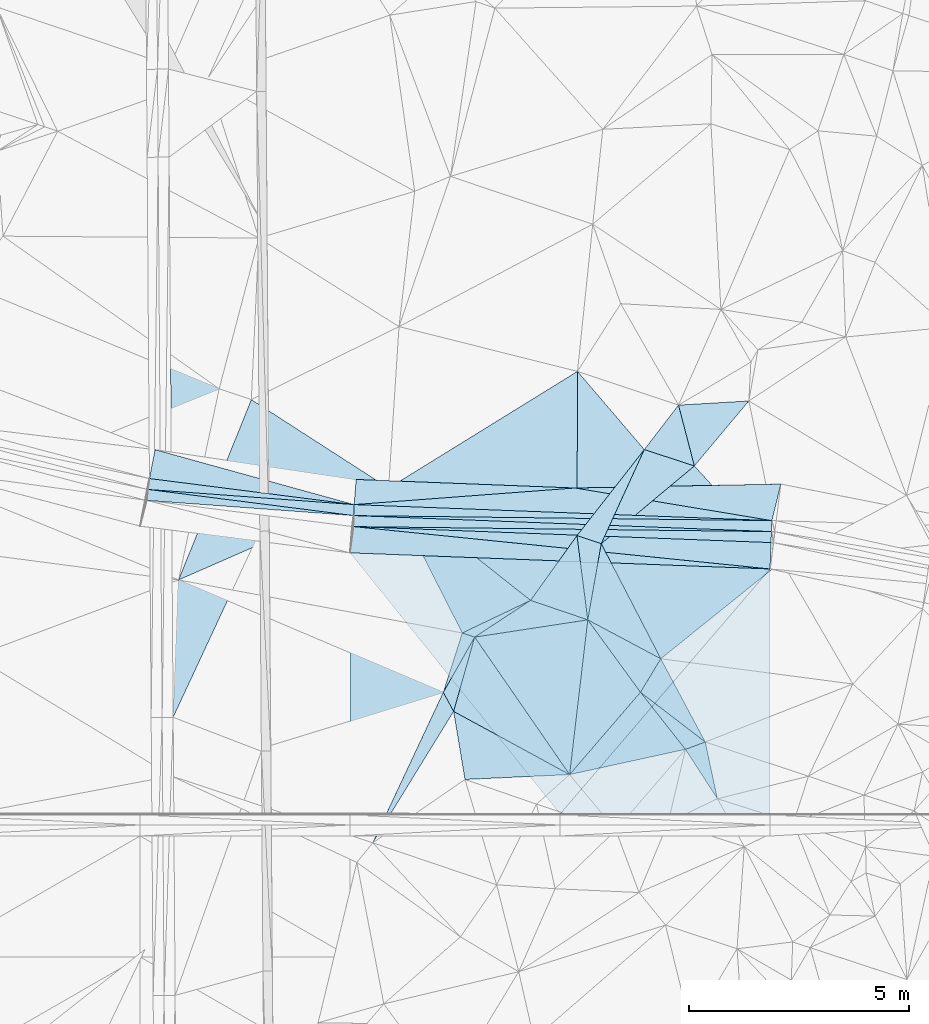
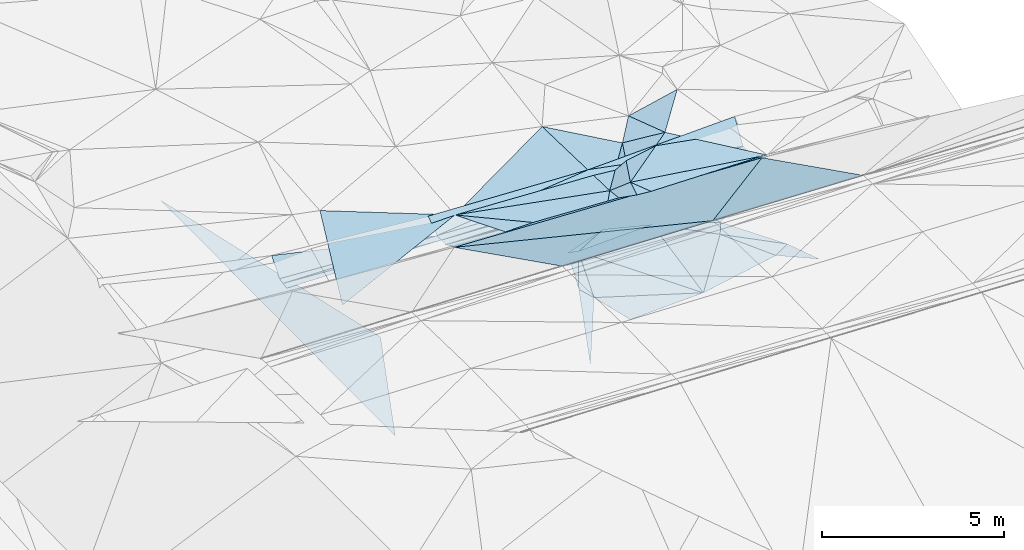
# One storey, part 115 of 275: 45 plates.
"""IFC2X3 building model written with IfcOpenShell, lengths in millimetres."""

import ifcopenshell
import ifcopenshell.guid

model = None  # the IFC model being written
_history = None  # IfcOwnerHistory: only IFC2X3 demands one
_inside = {}  # id of a spatial element -> (the spatial element, [elements in it])
_under = {}  # id of a project, library or spatial element -> (it, [spatial elements below it])
_declared = {}  # id of a project -> (the project, [libraries it declares])
_typed = {}  # id of a type object -> (the type object, [elements of that type])
_made_of = {}  # id of a material, layer set ... -> (it, [elements and type objects made of it])


def new_model(schema):
    """Start an empty IFC model of exactly this schema.

    Asked for "IFC4X3", IfcOpenShell would pick the latest addendum, in which some entities
    have other attributes; the version numbers below select the first issue.
    IFC2X3 requires an IfcOwnerHistory on every rooted entity: one is made here for all.
    """
    global model, _history
    if schema == "IFC4X3":
        model = ifcopenshell.file(schema_version=(4, 3, 0, 0))
    else:
        model = ifcopenshell.file(schema=schema)
    _inside.clear()
    _under.clear()
    _declared.clear()
    _typed.clear()
    _made_of.clear()
    _history = None
    if model.schema == "IFC2X3":
        org = make("IfcOrganization", Name="unknown")
        user = make(
            "IfcPersonAndOrganization",
            ThePerson=make("IfcPerson", FamilyName="unknown"),
            TheOrganization=org,
        )
        app = make(
            "IfcApplication",
            ApplicationDeveloper=org,
            Version="unknown",
            ApplicationFullName="unknown",
            ApplicationIdentifier="unknown",
        )
        _history = make(
            "IfcOwnerHistory",
            OwningUser=user,
            OwningApplication=app,
            ChangeAction="ADDED",
            CreationDate=0,
        )
    return model


def make(cls, **values):
    """One entity of the class cls with the attributes given. An attribute that is None is left unset."""
    return model.create_entity(
        cls, **{name: value for name, value in values.items() if value is not None}
    )


def rooted(cls, **values):
    """An entity with a GlobalId (a new one), such as an element, a storey or a relation."""
    return make(cls, GlobalId=ifcopenshell.guid.new(), OwnerHistory=_history, **values)


def si_unit(unit_type, name, prefix=None):
    """IfcSIUnit, for example si_unit("LENGTHUNIT", "METRE", prefix="MILLI")."""
    return make("IfcSIUnit", UnitType=unit_type, Prefix=prefix, Name=name)


def assignment(units):
    """IfcUnitAssignment: the units of a project."""
    return None if units is None else make("IfcUnitAssignment", Units=units)


def point(xyz):
    """IfcCartesianPoint."""
    return None if xyz is None else make("IfcCartesianPoint", Coordinates=xyz)


def direction(xyz):
    """IfcDirection."""
    return None if xyz is None else make("IfcDirection", DirectionRatios=xyz)


def frame(location, z_axis=None, x_axis=None):
    """IfcAxis2Placement3D, a coordinate frame: its origin and axes. An axis left out is left unset."""
    return make(
        "IfcAxis2Placement3D",
        Location=point(location),
        Axis=direction(z_axis),
        RefDirection=direction(x_axis),
    )


def origin_with_axes():
    """The frame at (0, 0, 0) with the z axis (0, 0, 1) and the x axis (1, 0, 0) written out."""
    return frame((0.0, 0.0, 0.0), z_axis=(0.0, 0.0, 1.0), x_axis=(1.0, 0.0, 0.0))


def place(relative_to, where):
    """IfcLocalPlacement: puts the frame where relative to a parent placement (None: the world)."""
    return make(
        "IfcLocalPlacement", PlacementRelTo=relative_to, RelativePlacement=where
    )


def context(
    kind, dimensions, precision=None, world=None, true_north=None, identifier=None
):
    """IfcGeometricRepresentationContext, for example the 3D "Model" context."""
    return make(
        "IfcGeometricRepresentationContext",
        ContextIdentifier=identifier,
        ContextType=kind,
        CoordinateSpaceDimension=dimensions,
        Precision=precision,
        WorldCoordinateSystem=world,
        TrueNorth=true_north,
    )


def subcontext(parent, identifier, kind, view, scale=None):
    """IfcGeometricRepresentationSubContext, for example "Body" below "Model"."""
    return make(
        "IfcGeometricRepresentationSubContext",
        ContextIdentifier=identifier,
        ContextType=kind,
        ParentContext=parent,
        TargetScale=scale,
        TargetView=view,
    )


def project(units=None, contexts=None):
    """IfcProject with its units and contexts."""
    return rooted(
        "IfcProject",
        Name="project",
        RepresentationContexts=contexts,
        UnitsInContext=assignment(units),
    )


def spatial(cls, under=None, at=None, **own):
    """A site, building, storey or space (cls), placed at a placement, below another one or the project."""
    s = rooted(cls, ObjectPlacement=at, **own)
    if under is not None:
        _under.setdefault(under.id(), (under, []))[1].append(s)
    return s


def polyline(points):
    """IfcPolyline through the points."""
    return make("IfcPolyline", Points=[point(p) for p in points])


def outline(outer, holes=None, kind="AREA"):
    """IfcArbitraryClosedProfileDef: a profile drawn as a closed curve; with holes, ...WithVoids."""
    if holes is None:
        return make("IfcArbitraryClosedProfileDef", ProfileType=kind, OuterCurve=outer)
    return make(
        "IfcArbitraryProfileDefWithVoids",
        ProfileType=kind,
        OuterCurve=outer,
        InnerCurves=holes,
    )


def extrude(swept, where, along, depth):
    """IfcExtrudedAreaSolid: the profile swept, set in the frame where, extruded along a direction by depth."""
    return make(
        "IfcExtrudedAreaSolid",
        SweptArea=swept,
        Position=where,
        ExtrudedDirection=direction(along),
        Depth=depth,
    )


def shape(context_of_items, identifier, shape_type, items):
    """IfcShapeRepresentation: the items that make up one representation, for example the "Body"."""
    return make(
        "IfcShapeRepresentation",
        ContextOfItems=context_of_items,
        RepresentationIdentifier=identifier,
        RepresentationType=shape_type,
        Items=items,
    )


def material(Name=None, Category=None):
    """IfcMaterial."""
    return make("IfcMaterial", Name=Name, Category=Category)


def made_of(thing, what):
    """Note that an element or type object is made of a material, layer set ...; save() writes the relation."""
    if what is not None:
        _made_of.setdefault(what.id(), (what, []))[1].append(thing)
    return thing


def type_object(cls, material=None, **own):
    """A type object (cls), such as IfcWallType, which elements share."""
    return made_of(rooted(cls, **own), material)


def element(
    cls,
    number,
    at=None,
    inside=None,
    cuts=None,
    type_object=None,
    material=None,
    context=None,
    identifier="Body",
    shape_type=None,
    held_by="IfcProductDefinitionShape",
    body=None,
    shapes=None,
    **own,
):
    """One element of the class cls, such as IfcWall. Its Tag is "e" and its number.

    at: its placement. inside: the storey or other place that contains it. cuts: it is an
    opening in that element (IfcRelVoidsElement). A single representation is given by context,
    identifier, shape_type and body (its items); several are given by shapes. held_by: the class
    of the entity that holds the representations. save() writes the other relations.
    """
    e = rooted(cls, Tag="e%d" % number, ObjectPlacement=at, **own)
    if body is not None:
        shapes = [shape(context, identifier, shape_type, body)]
    if shapes is not None:
        e.Representation = make(held_by, Representations=shapes)
    if inside is not None:
        _inside.setdefault(inside.id(), (inside, []))[1].append(e)
    if cuts is not None:
        rooted(
            "IfcRelVoidsElement", RelatingBuildingElement=cuts, RelatedOpeningElement=e
        )
    if type_object is not None:
        _typed.setdefault(type_object.id(), (type_object, []))[1].append(e)
    return made_of(e, material)


def aggregate(whole, parts):
    """IfcRelAggregates: a whole, such as a stair, and the parts it consists of."""
    return rooted("IfcRelAggregates", RelatingObject=whole, RelatedObjects=parts)


def save(model, path):
    """Write the relations noted so far, then the file.

    IfcRelAggregates (storeys below a building ...), IfcRelContainedInSpatialStructure (elements
    in a storey), IfcRelDefinesByType, IfcRelAssociatesMaterial and IfcRelDeclares: one each for
    every whole, place, type object, material and project.
    """
    for whole, parts in _under.values():
        aggregate(whole, parts)
    for where, things in _inside.values():
        rooted(
            "IfcRelContainedInSpatialStructure",
            RelatedElements=things,
            RelatingStructure=where,
        )
    for kind, things in _typed.values():
        rooted("IfcRelDefinesByType", RelatedObjects=things, RelatingType=kind)
    for what, things in _made_of.values():
        rooted("IfcRelAssociatesMaterial", RelatedObjects=things, RelatingMaterial=what)
    for by, libraries in _declared.values():
        rooted("IfcRelDeclares", RelatingContext=by, RelatedDefinitions=libraries)
    model.write(path)


model = new_model("IFC2X3")

# Units and contexts
model_context = context("Model", 3, precision=1e-05, world=origin_with_axes())
body_context = subcontext(model_context, "Body", "Model", "MODEL_VIEW")
ifc_project = project(units=[si_unit("LENGTHUNIT", "METRE", prefix="MILLI"), si_unit("AREAUNIT", "SQUARE_METRE"), si_unit("VOLUMEUNIT", "CUBIC_METRE"), si_unit("MASSUNIT", "GRAM", prefix="KILO"), si_unit("TIMEUNIT", "SECOND"), si_unit("PLANEANGLEUNIT", "RADIAN"), si_unit("SOLIDANGLEUNIT", "STERADIAN"), si_unit("THERMODYNAMICTEMPERATUREUNIT", "DEGREE_CELSIUS"), si_unit("LUMINOUSINTENSITYUNIT", "LUMEN")], contexts=[model_context])

# Site, building, storey
site_placement = place(None, origin_with_axes())
site = spatial("IfcSite", under=ifc_project, at=site_placement, CompositionType="ELEMENT")
building_placement = place(site_placement, origin_with_axes())
building = spatial("IfcBuilding", under=site, at=building_placement, Name="Undefined", CompositionType="ELEMENT")
storey_placement = place(building_placement, origin_with_axes())
storey = spatial("IfcBuildingStorey", under=building, at=storey_placement, Name="Undefined", CompositionType="ELEMENT", Elevation=0.0)

# Plates
ifc_material = material()
plate_type_1 = type_object("IfcPlateType", PredefinedType="NOTDEFINED")
plate_1_placement = place(storey_placement, frame((-48294.1638789683, 73916.0486067391, 44928.8124257044), z_axis=(0.0352593844994931, -0.0212550121172629, -0.999152140699609), x_axis=(0.125694012946975, 0.991929064763121, -0.0166657009287537)))
element("IfcPlate", 1, at=plate_1_placement, inside=storey, type_object=plate_type_1, material=ifc_material, Name="00_PR", context=body_context, shape_type="SweptSolid", body=[
    extrude(outline(polyline([(0.0, 0.0), (250.034484863281, 6.54836185276508e-10), (244.383270263672, 4692.763671875), (0.0, 0.0)])), frame((-8.85201319254618e-08, 2.18876761149539e-07, -0.5000001331573), z_axis=(0.0, 0.0, 1.0), x_axis=(1.0, 0.0, 0.0)), (0.0, 0.0, 1.0), 1.0),
])
plate_2_placement = place(storey_placement, frame((-43620.39508708, 73322.0550243122, 45102.3810420952), z_axis=(-0.0121938043643869, -0.00344139705818809, -0.999919730739128), x_axis=(0.0381160409586329, 0.999265693644616, -0.00390396293327051)))
element("IfcPlate", 2, at=plate_2_placement, inside=storey, type_object=plate_type_1, material=ifc_material, Name="00_PR", context=body_context, shape_type="SweptSolid", body=[
    extrude(outline(polyline([(0.0, 0.0), (250.002349853516, -2.83762346953154e-10), (248.815231323242, 9503.3759765625), (0.0, 0.0)])), frame((-8.85201319254618e-08, 2.18876761149539e-07, -0.5000001331573), z_axis=(0.0, 0.0, 1.0), x_axis=(1.0, 0.0, 0.0)), (0.0, 0.0, 1.0), 1.0),
])
plate_3_placement = place(storey_placement, frame((-34124.7195421901, 72958.2183460982, 44986.8590393595), z_axis=(-0.0121527442326692, 0.000465623148121774, -0.999926044266624), x_axis=(-0.0382861419842661, -0.999266816887242, -6.99073876586366e-11)))
element("IfcPlate", 3, at=plate_3_placement, inside=storey, type_object=plate_type_1, material=ifc_material, Name="00_PR", context=body_context, shape_type="SweptSolid", body=[
    extrude(outline(polyline([(0.0, 0.0), (250.000045776367, 1.01863406598568e-09), (249.981430053711, 9498.8671875), (0.0, 0.0)])), frame((-8.85201319254618e-08, 2.18876761149539e-07, -0.5000001331573), z_axis=(0.0, 0.0, 1.0), x_axis=(1.0, 0.0, 0.0)), (0.0, 0.0, 1.0), 1.0),
])
plate_4_placement = place(storey_placement, frame((-43625.490880471, 73072.068163486, 45102.3810387833), z_axis=(-0.0121553558488457, 0.000247777014239796, -0.999926090234043), x_axis=(0.0203799450012853, 0.999792307352754, 6.91103637420199e-11)))
element("IfcPlate", 4, at=plate_4_placement, inside=storey, type_object=plate_type_1, material=ifc_material, Name="00_PR", context=body_context, shape_type="SweptSolid", body=[
    extrude(outline(polyline([(0.0, 0.0), (250.040634155273, -9.67702362686396e-10), (79.7989196777344, 9501.8203125), (0.0, 0.0)])), frame((-8.85201319254618e-08, 2.18876761149539e-07, -0.5000001331573), z_axis=(0.0, 0.0, 1.0), x_axis=(1.0, 0.0, 0.0)), (0.0, 0.0, 1.0), 1.0),
])
plate_5_placement = place(storey_placement, frame((-48318.9873284773, 73667.2003650453, 44928.8123364853), z_axis=(0.036441065400132, -0.00363507658490201, -0.999329192494008), x_axis=(0.0992595869970328, 0.995061573164786, 7.62530437417146e-11)))
element("IfcPlate", 5, at=plate_5_placement, inside=storey, type_object=plate_type_1, material=ifc_material, Name="00_PR", context=body_context, shape_type="SweptSolid", body=[
    extrude(outline(polyline([(0.0, 0.0), (250.09211730957, 0.0), (122.941780090332, 4712.8330078125), (0.0, 0.0)])), frame((-8.85201319254618e-08, 2.18876761149539e-07, -0.5000001331573), z_axis=(0.0, 0.0, 1.0), x_axis=(1.0, 0.0, 0.0)), (0.0, 0.0, 1.0), 1.0),
])
plate_6_placement = place(storey_placement, frame((-34115.1480022174, 73208.0351007316, 44986.8590386004), z_axis=(-0.0121470174228114, 0.000465403730693247, -0.999926113953975), x_axis=(-0.0382861419842661, -0.999266816887242, -6.99073876586366e-11)))
element("IfcPlate", 6, at=plate_6_placement, inside=storey, type_object=plate_type_1, material=ifc_material, Name="00_PR", context=body_context, shape_type="SweptSolid", body=[
    extrude(outline(polyline([(0.0, 0.0), (250.000045776367, 1.01863406598568e-09), (249.98095703125, 9503.345703125), (0.0, 0.0)])), frame((-8.85201319254618e-08, 2.18876761149539e-07, -0.5000001331573), z_axis=(0.0, 0.0, 1.0), x_axis=(1.0, 0.0, 0.0)), (0.0, 0.0, 1.0), 1.0),
])
plate_type_2 = type_object("IfcPlateType", PredefinedType="NOTDEFINED")
plate_7_placement = place(storey_placement, frame((-47815.5257000505, 81469.3146674335, 42970.4690775607), z_axis=(-0.000186197747615207, 0.0175987070443489, -0.999845113425458), x_axis=(0.235525740042379, -0.971716826060535, -0.0171474700270998)))
element("IfcPlate", 7, at=plate_7_placement, inside=storey, type_object=plate_type_2, material=ifc_material, Name="00_PR", context=body_context, shape_type="SweptSolid", body=[
    extrude(outline(polyline([(0.0, 0.0), (8751.0869140625, 1.57961039803922e-08), (12397.4677734375, 2910.38232421875), (0.0, 0.0)])), frame((-8.85201319254618e-08, 2.18876761149539e-07, -0.5000001331573), z_axis=(0.0, 0.0, 1.0), x_axis=(1.0, 0.0, 0.0)), (0.0, 0.0, 1.0), 1.0),
])
plate_type_3 = type_object("IfcPlateType", PredefinedType="NOTDEFINED")
plate_8_placement = place(storey_placement, frame((-38299.7541736473, 70952.5999806547, 45199.5002545505), z_axis=(-0.0129765998053604, 0.029664067349419, -0.99947568803137), x_axis=(-0.946487294587573, 0.322000893554466, 0.0218454968911747)))
element("IfcPlate", 8, at=plate_8_placement, inside=storey, type_object=plate_type_3, material=ifc_material, Name="00", context=body_context, shape_type="SweptSolid", body=[
    extrude(outline(polyline([(0.0, 0.0), (1373.28076171875, -1.00408215075731e-09), (849.644165039063, 1733.98522949219), (0.0, 0.0)])), frame((-8.85201319254618e-08, 2.18876761149539e-07, -0.5000001331573), z_axis=(0.0, 0.0, 1.0), x_axis=(1.0, 0.0, 0.0)), (0.0, 0.0, 1.0), 1.0),
])
plate_type_4 = type_object("IfcPlateType", PredefinedType="NOTDEFINED")
plate_9_placement = place(storey_placement, frame((-36237.0662744395, 75833.3351531522, 45159.5058776926), z_axis=(0.130062658848475, -0.0805188598307914, -0.9882309537678), x_axis=(0.250259449661486, -0.961760215188191, 0.111299129988942)))
element("IfcPlate", 9, at=plate_9_placement, inside=storey, type_object=plate_type_4, material=ifc_material, Name="00", context=body_context, shape_type="SweptSolid", body=[
    extrude(outline(polyline([(0.0, 0.0), (1437.5673828125, -6.98491930961609e-09), (775.268005371094, 1012.84722900391), (0.0, 0.0)])), frame((-8.85201319254618e-08, 2.18876761149539e-07, -0.5000001331573), z_axis=(0.0, 0.0, 1.0), x_axis=(1.0, 0.0, 0.0)), (0.0, 0.0, 1.0), 1.0),
])
plate_type_5 = type_object("IfcPlateType", PredefinedType="NOTDEFINED")
plate_10_placement = place(storey_placement, frame((-38544.5682656878, 72867.0351067597, 45259.5354862471), z_axis=(0.362270625941178, 0.0754788503161102, -0.929011806563913), x_axis=(0.897348791674895, -0.297765596324914, 0.325731170944499)))
element("IfcPlate", 10, at=plate_10_placement, inside=storey, type_object=plate_type_5, material=ifc_material, Name="00", context=body_context, shape_type="SweptSolid", body=[
    extrude(outline(polyline([(0.0, 0.0), (614.003234863281, 3.49245965480804e-10), (770.354248046875, 1770.63671875), (0.0, 0.0)])), frame((-8.85201319254618e-08, 2.18876761149539e-07, -0.5000001331573), z_axis=(0.0, 0.0, 1.0), x_axis=(1.0, 0.0, 0.0)), (0.0, 0.0, 1.0), 1.0),
])
plate_type_6 = type_object("IfcPlateType", PredefinedType="NOTDEFINED")
plate_11_placement = place(storey_placement, frame((-43610.8415277604, 73571.8748104233, 45101.4053396319), z_axis=(0.036724844030492, -0.00140083422017048, -0.999324433552199), x_axis=(-0.0381163309563892, -0.999273308617028, -6.34171355241828e-11)))
element("IfcPlate", 11, at=plate_11_placement, inside=storey, type_object=plate_type_6, material=ifc_material, Name="00_PR", context=body_context, shape_type="SweptSolid", body=[
    extrude(outline(polyline([(0.0, 0.0), (250.000442504883, 1.2732925824821e-09), (-165.422576904297, 4696.2099609375), (0.0, 0.0)])), frame((-8.85201319254618e-08, 2.18876761149539e-07, -0.5000001331573), z_axis=(0.0, 0.0, 1.0), x_axis=(1.0, 0.0, 0.0)), (0.0, 0.0, 1.0), 1.0),
])
plate_type_7 = type_object("IfcPlateType", PredefinedType="NOTDEFINED")
plate_12_placement = place(storey_placement, frame((-35877.2814056823, 74450.74555178, 45319.5085100628), z_axis=(0.170148167788889, -0.0694789403392727, -0.982966061391448), x_axis=(-0.250259449654528, 0.961760215189894, -0.111299129989871)))
element("IfcPlate", 12, at=plate_12_placement, inside=storey, type_object=plate_type_7, material=ifc_material, Name="00", context=body_context, shape_type="SweptSolid", body=[
    extrude(outline(polyline([(0.0, 0.0), (1437.5673828125, -6.98491930961609e-09), (1098.244140625, 1587.87902832031), (0.0, 0.0)])), frame((-8.85201319254618e-08, 2.18876761149539e-07, -0.5000001331573), z_axis=(0.0, 0.0, 1.0), x_axis=(1.0, 0.0, 0.0)), (0.0, 0.0, 1.0), 1.0),
])
plate_type_8 = type_object("IfcPlateType", PredefinedType="NOTDEFINED")
plate_13_placement = place(storey_placement, frame((-39599.5745177259, 71394.7162026286, 45229.5056149073), z_axis=(-0.068114263041179, -0.133134566190392, -0.988754587577551), x_axis=(0.946487294584048, -0.322000893564711, -0.0218454968929094)))
element("IfcPlate", 13, at=plate_13_placement, inside=storey, type_object=plate_type_8, material=ifc_material, Name="00", context=body_context, shape_type="SweptSolid", body=[
    extrude(outline(polyline([(0.0, 0.0), (1373.28076171875, -1.00408215075731e-09), (-938.264099121094, 1213.326171875), (0.0, 0.0)])), frame((-8.85201319254618e-08, 2.18876761149539e-07, -0.5000001331573), z_axis=(0.0, 0.0, 1.0), x_axis=(1.0, 0.0, 0.0)), (0.0, 0.0, 1.0), 1.0),
])
plate_type_9 = type_object("IfcPlateType", PredefinedType="NOTDEFINED")
plate_14_placement = place(storey_placement, frame((-38929.7485345879, 66538.8973948599, 48227.293977892), z_axis=(-0.0291366779569106, -0.447022289399467, -0.894048168041127), x_axis=(0.603945609128196, 0.704835044183428, -0.37209845700529)))
element("IfcPlate", 14, at=plate_14_placement, inside=storey, type_object=plate_type_9, material=ifc_material, Name="00_PR", context=body_context, shape_type="SweptSolid", body=[
    extrude(outline(polyline([(0.0, 0.0), (7902.1611328125, 1.81171344593167e-08), (2939.74926757813, 3762.37939453125), (0.0, 0.0)])), frame((-8.85201319254618e-08, 2.18876761149539e-07, -0.5000001331573), z_axis=(0.0, 0.0, 1.0), x_axis=(1.0, 0.0, 0.0)), (0.0, 0.0, 1.0), 1.0),
])
plate_type_10 = type_object("IfcPlateType", PredefinedType="NOTDEFINED")
plate_15_placement = place(storey_placement, frame((-43701.9052193677, 66539.1712990873, 48370.0079480461), z_axis=(-0.0267644317750755, -0.447052184448711, -0.894107381454483), x_axis=(5.12540063995904e-05, 0.894427178851963, -0.447213616858817)))
element("IfcPlate", 15, at=plate_15_placement, inside=storey, type_object=plate_type_10, material=ifc_material, Name="00_PR", context=body_context, shape_type="SweptSolid", body=[
    extrude(outline(polyline([(0.0, 0.0), (6635.69677734375, -4.10727807320654e-08), (63.8232383728027, 4773.86474609375), (0.0, 0.0)])), frame((-8.85201319254618e-08, 2.18876761149539e-07, -0.5000001331573), z_axis=(0.0, 0.0, 1.0), x_axis=(1.0, 0.0, 0.0)), (0.0, 0.0, 1.0), 1.0),
])
plate_type_11 = type_object("IfcPlateType", PredefinedType="NOTDEFINED")
plate_16_placement = place(storey_placement, frame((-43701.5657190606, 72474.3185491904, 45402.4341603387), z_axis=(-0.0279758974554094, -0.447824506830686, -0.893683702572346), x_axis=(0.999193658655912, -0.0382853399598579, -0.0120940169493687)))
element("IfcPlate", 16, at=plate_16_placement, inside=storey, type_object=plate_type_11, material=ifc_material, Name="00_PR", context=body_context, shape_type="SweptSolid", body=[
    extrude(outline(polyline([(0.0, 0.0), (9551.9951171875, 2.2650056052953e-08), (4961.0458984375, 6431.744140625), (0.0, 0.0)])), frame((-8.85201319254618e-08, 2.18876761149539e-07, -0.5000001331573), z_axis=(0.0, 0.0, 1.0), x_axis=(1.0, 0.0, 0.0)), (0.0, 0.0, 1.0), 1.0),
])
plate_type_12 = type_object("IfcPlateType", PredefinedType="NOTDEFINED")
plate_17_placement = place(storey_placement, frame((-38592.7471296387, 73948.981692598, 45325.5578146651), z_axis=(0.00634905510880159, 0.447272560610133, -0.894375170733446), x_axis=(0.98385623282785, -0.162757673921321, -0.074410030946857)))
element("IfcPlate", 17, at=plate_17_placement, inside=storey, type_object=plate_type_12, material=ifc_material, Name="00_PR", context=body_context, shape_type="SweptSolid", body=[
    extrude(outline(polyline([(0.0, 0.0), (4551.080078125, 1.83354131877422e-08), (-4859.08251953125, 1327.78063964844), (0.0, 0.0)])), frame((-8.85201319254618e-08, 2.18876761149539e-07, -0.5000001331573), z_axis=(0.0, 0.0, 1.0), x_axis=(1.0, 0.0, 0.0)), (0.0, 0.0, 1.0), 1.0),
])
plate_type_13 = type_object("IfcPlateType", PredefinedType="NOTDEFINED")
plate_18_placement = place(storey_placement, frame((-43610.8150517219, 73572.094188463, 45101.4575983026), z_axis=(0.089676798882238, 0.437353470869262, -0.894807249222336), x_axis=(-0.991290193355337, 0.126194251010662, -0.0376664780593735)))
element("IfcPlate", 18, at=plate_18_placement, inside=storey, type_object=plate_type_13, material=ifc_material, Name="00_PR", context=body_context, shape_type="SweptSolid", body=[
    extrude(outline(polyline([(0.0, 0.0), (4692.76708984375, -3.52156348526478e-09), (4636.18798828125, 745.3203125), (0.0, 0.0)])), frame((-8.85201319254618e-08, 2.18876761149539e-07, -0.5000001331573), z_axis=(0.0, 0.0, 1.0), x_axis=(1.0, 0.0, 0.0)), (0.0, 0.0, 1.0), 1.0),
])
plate_type_14 = type_object("IfcPlateType", PredefinedType="NOTDEFINED")
plate_19_placement = place(storey_placement, frame((-43610.856734318, 73572.0993404267, 45101.4579101717), z_axis=(0.00631165794753538, 0.447656440952381, -0.89418335583246), x_axis=(0.0736856039742988, 0.891561999333182, 0.446864222233066)))
element("IfcPlate", 19, at=plate_19_placement, inside=storey, type_object=plate_type_14, material=ifc_material, Name="00_PR", context=body_context, shape_type="SweptSolid", body=[
    extrude(outline(polyline([(0.0, 0.0), (640.6845703125, 4.63478500023484e-09), (805.918884277344, 4972.34130859375), (0.0, 0.0)])), frame((-8.85201319254618e-08, 2.18876761149539e-07, -0.5000001331573), z_axis=(0.0, 0.0, 1.0), x_axis=(1.0, 0.0, 0.0)), (0.0, 0.0, 1.0), 1.0),
])
plate_type_15 = type_object("IfcPlateType", PredefinedType="NOTDEFINED")
plate_20_placement = place(storey_placement, frame((-34115.1379912368, 73208.2622473033, 44986.9137125521), z_axis=(0.00787472547626371, 0.45475972402133, -0.890579351942721), x_axis=(-0.983856232823645, 0.162757673944208, 0.0744100309523982)))
element("IfcPlate", 20, at=plate_20_placement, inside=storey, type_object=plate_type_15, material=ifc_material, Name="00_PR", context=body_context, shape_type="SweptSolid", body=[
    extrude(outline(polyline([(0.0, 0.0), (4551.080078125, 1.83354131877422e-08), (-34.1831550598145, 954.719665527344), (0.0, 0.0)])), frame((-8.85201319254618e-08, 2.18876761149539e-07, -0.5000001331573), z_axis=(0.0, 0.0, 1.0), x_axis=(1.0, 0.0, 0.0)), (0.0, 0.0, 1.0), 1.0),
])
plate_type_16 = type_object("IfcPlateType", PredefinedType="NOTDEFINED")
plate_21_placement = place(storey_placement, frame((-34134.2989981631, 72708.1781411806, 44986.911815069), z_axis=(-0.0279918454112307, -0.446442565480582, -0.894374358038954), x_axis=(-0.0342467030104274, -0.893771397797463, 0.447213429820801)))
element("IfcPlate", 21, at=plate_21_placement, inside=storey, type_object=plate_type_16, material=ifc_material, Name="00_PR", context=body_context, shape_type="SweptSolid", body=[
    extrude(outline(polyline([(0.0, 0.0), (670.820617675781, -4.27826307713985e-09), (51.6704139709473, 9498.7265625), (0.0, 0.0)])), frame((-8.85201319254618e-08, 2.18876761149539e-07, -0.5000001331573), z_axis=(0.0, 0.0, 1.0), x_axis=(1.0, 0.0, 0.0)), (0.0, 0.0, 1.0), 1.0),
])
plate_type_17 = type_object("IfcPlateType", PredefinedType="NOTDEFINED")
plate_22_placement = place(storey_placement, frame((-43625.4987565235, 73071.8452011288, 45102.4336228611), z_axis=(-0.0279066886420588, -0.445678930271046, -0.894757792836414), x_axis=(0.994678216645492, -0.101191168950948, 0.0193802130350836)))
element("IfcPlate", 22, at=plate_22_placement, inside=storey, type_object=plate_type_17, material=ifc_material, Name="00_PR", context=body_context, shape_type="SweptSolid", body=[
    extrude(outline(polyline([(0.0, 0.0), (9518.8837890625, -2.69938027486205e-09), (-9.38374137878418, 672.855834960938), (0.0, 0.0)])), frame((-8.85201319254618e-08, 2.18876761149539e-07, -0.5000001331573), z_axis=(0.0, 0.0, 1.0), x_axis=(1.0, 0.0, 0.0)), (0.0, 0.0, 1.0), 1.0),
])
plate_type_18 = type_object("IfcPlateType", PredefinedType="NOTDEFINED")
plate_23_placement = place(storey_placement, frame((-35353.9332675903, 66886.3902669286, 45479.5242244663), z_axis=(0.299687345489881, -0.0690176634689884, -0.951537732873747), x_axis=(-0.52897916325941, 0.81800649136377, -0.225934558941541)))
element("IfcPlate", 23, at=plate_23_placement, inside=storey, type_object=plate_type_18, material=ifc_material, Name="00", context=body_context, shape_type="SweptSolid", body=[
    extrude(outline(polyline([(0.0, 0.0), (1372.07873535156, 6.75026967655867e-09), (1240.38073730469, 480.474395751953), (0.0, 0.0)])), frame((-8.85201319254618e-08, 2.18876761149539e-07, -0.5000001331573), z_axis=(0.0, 0.0, 1.0), x_axis=(1.0, 0.0, 0.0)), (0.0, 0.0, 1.0), 1.0),
])
plate_type_19 = type_object("IfcPlateType", PredefinedType="NOTDEFINED")
plate_24_placement = place(storey_placement, frame((-41583.5466502229, 69304.0973027181, 45179.5076001408), z_axis=(0.0549240151798928, 0.164880045948497, -0.984783185784841), x_axis=(0.299675360539065, 0.938081587537409, 0.173774605190389)))
element("IfcPlate", 24, at=plate_24_placement, inside=storey, type_object=plate_type_19, material=ifc_material, Name="00", context=body_context, shape_type="SweptSolid", body=[
    extrude(outline(polyline([(0.0, 0.0), (1438.64514160156, -9.64791979640722e-09), (1435.03063964844, 297.299407958984), (0.0, 0.0)])), frame((-8.85201319254618e-08, 2.18876761149539e-07, -0.5000001331573), z_axis=(0.0, 0.0, 1.0), x_axis=(1.0, 0.0, 0.0)), (0.0, 0.0, 1.0), 1.0),
])
plate_type_20 = type_object("IfcPlateType", PredefinedType="NOTDEFINED")
plate_25_placement = place(storey_placement, frame((-40870.3795829874, 70559.7209591459, 45429.5114313044), z_axis=(-0.0284712110052367, 0.210726622279353, -0.977130329488667), x_axis=(-0.267512567466023, -0.943476866314357, -0.195674293092826)))
element("IfcPlate", 25, at=plate_25_placement, inside=storey, type_object=plate_type_20, material=ifc_material, Name="00", context=body_context, shape_type="SweptSolid", body=[
    extrude(outline(polyline([(0.0, 0.0), (1788.68664550781, -1.30457920022309e-08), (1424.34118652344, 344.894653320313), (0.0, 0.0)])), frame((-8.85201319254618e-08, 2.18876761149539e-07, -0.5000001331573), z_axis=(0.0, 0.0, 1.0), x_axis=(1.0, 0.0, 0.0)), (0.0, 0.0, 1.0), 1.0),
])
plate_type_21 = type_object("IfcPlateType", PredefinedType="NOTDEFINED")
plate_26_placement = place(storey_placement, frame((-40870.2997827606, 70559.6983713795, 45429.5112648582), z_axis=(0.131032700936032, 0.165568289884683, -0.977454639699495), x_axis=(0.567103270465185, -0.821227432631906, -0.0630823629907774)))
element("IfcPlate", 26, at=plate_26_placement, inside=storey, type_object=plate_type_21, material=ifc_material, Name="00", context=body_context, shape_type="SweptSolid", body=[
    extrude(outline(polyline([(0.0, 0.0), (3804.5498046875, -2.38696884480305e-08), (1136.61279296875, 1381.12683105469), (0.0, 0.0)])), frame((-8.85201319254618e-08, 2.18876761149539e-07, -0.5000001331573), z_axis=(0.0, 0.0, 1.0), x_axis=(1.0, 0.0, 0.0)), (0.0, 0.0, 1.0), 1.0),
])
plate_type_22 = type_object("IfcPlateType", PredefinedType="NOTDEFINED")
plate_27_placement = place(storey_placement, frame((-39599.5412497091, 71394.7935210835, 45229.500108391), z_axis=(-0.00157764229593975, 0.0215030540138661, -0.999767537837103), x_axis=(-0.784264641186151, 0.620255151378769, 0.0145780579385009)))
element("IfcPlate", 27, at=plate_27_placement, inside=storey, type_object=plate_type_22, material=ifc_material, Name="00", context=body_context, shape_type="SweptSolid", body=[
    extrude(outline(polyline([(0.0, 0.0), (4115.7744140625, 2.27664713747799e-08), (86.350700378418, 1809.26599121094), (0.0, 0.0)])), frame((-8.85201319254618e-08, 2.18876761149539e-07, -0.5000001331573), z_axis=(0.0, 0.0, 1.0), x_axis=(1.0, 0.0, 0.0)), (0.0, 0.0, 1.0), 1.0),
])
plate_type_23 = type_object("IfcPlateType", PredefinedType="NOTDEFINED")
plate_28_placement = place(storey_placement, frame((-37993.7278375206, 72684.0738952864, 45459.5111949757), z_axis=(0.0929685365843155, -0.188848888630725, -0.977595493273323), x_axis=(0.412439055346512, 0.900953590015733, -0.134820822808049)))
element("IfcPlate", 28, at=plate_28_placement, inside=storey, type_object=plate_type_23, material=ifc_material, Name="00", context=body_context, shape_type="SweptSolid", body=[
    extrude(outline(polyline([(0.0, 0.0), (2373.5205078125, 3.01224645227194e-09), (2483.39965820313, 1205.16662597656), (0.0, 0.0)])), frame((-8.85201319254618e-08, 2.18876761149539e-07, -0.5000001331573), z_axis=(0.0, 0.0, 1.0), x_axis=(1.0, 0.0, 0.0)), (0.0, 0.0, 1.0), 1.0),
])
plate_type_24 = type_object("IfcPlateType", PredefinedType="NOTDEFINED")
plate_29_placement = place(storey_placement, frame((-37101.7473546847, 69306.5449879189, 45449.5324559002), z_axis=(0.150989672756199, 0.320688624988727, -0.93507268408601), x_axis=(0.790620145356859, -0.606991299525762, -0.0805068199342481)))
element("IfcPlate", 29, at=plate_29_placement, inside=storey, type_object=plate_type_24, material=ifc_material, Name="00", context=body_context, shape_type="SweptSolid", body=[
    extrude(outline(polyline([(0.0, 0.0), (1863.19616699219, -6.98491930961609e-09), (1618.13342285156, 433.755981445313), (0.0, 0.0)])), frame((-8.85201319254618e-08, 2.18876761149539e-07, -0.5000001331573), z_axis=(0.0, 0.0, 1.0), x_axis=(1.0, 0.0, 0.0)), (0.0, 0.0, 1.0), 1.0),
])
plate_type_25 = type_object("IfcPlateType", PredefinedType="NOTDEFINED")
plate_30_placement = place(storey_placement, frame((-38299.7975276079, 70952.4751884007, 45199.5147860152), z_axis=(-0.0996872585531978, -0.219913067900185, -0.970412640606498), x_axis=(0.88233312402189, -0.47035497035357, 0.0159518060878292)))
element("IfcPlate", 30, at=plate_30_placement, inside=storey, type_object=plate_type_25, material=ifc_material, Name="00", context=body_context, shape_type="SweptSolid", body=[
    extrude(outline(polyline([(0.0, 0.0), (1880.66479492188, -3.87080945074558e-09), (1835.25524902344, 916.153930664063), (0.0, 0.0)])), frame((-8.85201319254618e-08, 2.18876761149539e-07, -0.5000001331573), z_axis=(0.0, 0.0, 1.0), x_axis=(1.0, 0.0, 0.0)), (0.0, 0.0, 1.0), 1.0),
])
plate_type_26 = type_object("IfcPlateType", PredefinedType="NOTDEFINED")
plate_31_placement = place(storey_placement, frame((-41583.6970174625, 69304.0597953836, 45179.5174203994), z_axis=(-0.245811793385554, 0.0898625825191768, -0.965143138863641), x_axis=(0.467837344735942, -0.861044936057803, -0.199323448092885)))
element("IfcPlate", 31, at=plate_31_placement, inside=storey, type_object=plate_type_26, material=ifc_material, Name="00", context=body_context, shape_type="SweptSolid", body=[
    extrude(outline(polyline([(0.0, 0.0), (501.697113037109, -1.30239641293883e-09), (2177.0107421875, 3088.95190429688), (0.0, 0.0)])), frame((-8.85201319254618e-08, 2.18876761149539e-07, -0.5000001331573), z_axis=(0.0, 0.0, 1.0), x_axis=(1.0, 0.0, 0.0)), (0.0, 0.0, 1.0), 1.0),
])
plate_type_27 = type_object("IfcPlateType", PredefinedType="NOTDEFINED")
plate_32_placement = place(storey_placement, frame((-42827.4402266736, 73947.570002632, 45289.5037428693), z_axis=(-0.0866590266152979, -0.0862466373406698, -0.99249772324853), x_axis=(0.784264641187346, -0.620255151377229, -0.01457805793974)))
element("IfcPlate", 32, at=plate_32_placement, inside=storey, type_object=plate_type_27, material=ifc_material, Name="00", context=body_context, shape_type="SweptSolid", body=[
    extrude(outline(polyline([(0.0, 0.0), (4115.7744140625, 2.27664713747799e-08), (3354.70263671875, 1556.17150878906), (0.0, 0.0)])), frame((-8.85201319254618e-08, 2.18876761149539e-07, -0.5000001331573), z_axis=(0.0, 0.0, 1.0), x_axis=(1.0, 0.0, 0.0)), (0.0, 0.0, 1.0), 1.0),
])
plate_type_28 = type_object("IfcPlateType", PredefinedType="NOTDEFINED")
plate_33_placement = place(storey_placement, frame((-36640.3305933518, 70068.0714125098, 45229.5063874835), z_axis=(0.0885280703063098, 0.132588095295436, -0.987209794194613), x_axis=(-0.882333124025506, 0.470354970346742, -0.0159518060891481)))
element("IfcPlate", 33, at=plate_33_placement, inside=storey, type_object=plate_type_28, material=ifc_material, Name="00", context=body_context, shape_type="SweptSolid", body=[
    extrude(outline(polyline([(0.0, 0.0), (1880.66479492188, -3.87080945074558e-09), (2421.00561523438, 1693.40832519531), (0.0, 0.0)])), frame((-8.85201319254618e-08, 2.18876761149539e-07, -0.5000001331573), z_axis=(0.0, 0.0, 1.0), x_axis=(1.0, 0.0, 0.0)), (0.0, 0.0, 1.0), 1.0),
])
plate_type_29 = type_object("IfcPlateType", PredefinedType="NOTDEFINED")
plate_34_placement = place(storey_placement, frame((-37993.6474450591, 72684.0404435587, 45459.5335695879), z_axis=(0.253749554901718, -0.255754815066499, -0.932845452343249), x_axis=(-0.897348791670783, 0.297765596336899, -0.325731170944872)))
element("IfcPlate", 34, at=plate_34_placement, inside=storey, type_object=plate_type_29, material=ifc_material, Name="00", context=body_context, shape_type="SweptSolid", body=[
    extrude(outline(polyline([(0.0, 0.0), (614.003234863281, 3.49245965480804e-10), (-137.458557128906, 2369.53686523438), (0.0, 0.0)])), frame((-8.85201319254618e-08, 2.18876761149539e-07, -0.5000001331573), z_axis=(0.0, 0.0, 1.0), x_axis=(1.0, 0.0, 0.0)), (0.0, 0.0, 1.0), 1.0),
])
plate_type_30 = type_object("IfcPlateType", PredefinedType="NOTDEFINED")
plate_35_placement = place(storey_placement, frame((-38712.8381831187, 67435.221602958, 45189.5021198306), z_axis=(-0.0911611221949305, 0.0135359869884323, -0.995744157329788), x_axis=(-0.567103270459236, 0.821227432636047, 0.0630823629903364)))
element("IfcPlate", 35, at=plate_35_placement, inside=storey, type_object=plate_type_30, material=ifc_material, Name="00", context=body_context, shape_type="SweptSolid", body=[
    extrude(outline(polyline([(0.0, 0.0), (3804.5498046875, -2.38696884480305e-08), (2654.95263671875, 2343.89135742188), (0.0, 0.0)])), frame((-8.85201319254618e-08, 2.18876761149539e-07, -0.5000001331573), z_axis=(0.0, 0.0, 1.0), x_axis=(1.0, 0.0, 0.0)), (0.0, 0.0, 1.0), 1.0),
])
plate_type_31 = type_object("IfcPlateType", PredefinedType="NOTDEFINED")
plate_36_placement = place(storey_placement, frame((-38533.3769091236, 76600.3940521797, 45139.5005997766), z_axis=(-0.0374511391869874, -0.0319888945290303, -0.998786324896575), x_axis=(0.649478569191619, -0.76037989726242, 4.18124368691945e-11)))
element("IfcPlate", 36, at=plate_36_placement, inside=storey, type_object=plate_type_31, material=ifc_material, Name="00", context=body_context, shape_type="SweptSolid", body=[
    extrude(outline(polyline([(0.0, 0.0), (2338.0546875, -6.63567334413528e-09), (2831.41357421875, 2436.39013671875), (0.0, 0.0)])), frame((-8.85201319254618e-08, 2.18876761149539e-07, -0.5000001331573), z_axis=(0.0, 0.0, 1.0), x_axis=(1.0, 0.0, 0.0)), (0.0, 0.0, 1.0), 1.0),
])
plate_type_32 = type_object("IfcPlateType", PredefinedType="NOTDEFINED")
plate_37_placement = place(storey_placement, frame((-35628.849031705, 68175.365929634, 45299.5172595735), z_axis=(-0.213233444194662, -0.149689225798747, -0.965466019058493), x_axis=(-0.790620145360205, 0.606991299520854, 0.0805068199384026)))
element("IfcPlate", 37, at=plate_37_placement, inside=storey, type_object=plate_type_32, material=ifc_material, Name="00", context=body_context, shape_type="SweptSolid", body=[
    extrude(outline(polyline([(0.0, 0.0), (1863.19616699219, -6.98491930961609e-09), (1942.95166015625, 913.804748535156), (0.0, 0.0)])), frame((-8.85201319254618e-08, 2.18876761149539e-07, -0.5000001331573), z_axis=(0.0, 0.0, 1.0), x_axis=(1.0, 0.0, 0.0)), (0.0, 0.0, 1.0), 1.0),
])
plate_type_33 = type_object("IfcPlateType", PredefinedType="NOTDEFINED")
plate_38_placement = place(storey_placement, frame((-38533.3657301378, 76600.394007485, 45139.5003071578), z_axis=(-0.0150941405548781, -0.0320759163727116, -0.999371453719667), x_axis=(-0.00304956538475873, -0.999479192703989, 0.0321254338919642)))
element("IfcPlate", 38, at=plate_38_placement, inside=storey, type_object=plate_type_33, material=ifc_material, Name="00", context=body_context, shape_type="SweptSolid", body=[
    extrude(outline(polyline([(0.0, 0.0), (3735.35815429688, -1.46537786349654e-08), (2669.3291015625, 4286.40673828125), (0.0, 0.0)])), frame((-8.85201319254618e-08, 2.18876761149539e-07, -0.5000001331573), z_axis=(0.0, 0.0, 1.0), x_axis=(1.0, 0.0, 0.0)), (0.0, 0.0, 1.0), 1.0),
])
plate_type_34 = type_object("IfcPlateType", PredefinedType="NOTDEFINED")
plate_39_placement = place(storey_placement, frame((-37101.8457643289, 69306.4726874645, 45449.508338929), z_axis=(-0.0458301701776433, 0.176088147794012, -0.983306950910021), x_axis=(0.610017533613902, -0.774560170799782, -0.167138118016881)))
element("IfcPlate", 39, at=plate_39_placement, inside=storey, type_object=plate_type_34, material=ifc_material, Name="00", context=body_context, shape_type="SweptSolid", body=[
    extrude(outline(polyline([(0.0, 0.0), (1675.26123046875, -4.01996658183634e-09), (510.069732666016, 2429.80029296875), (0.0, 0.0)])), frame((-8.85201319254618e-08, 2.18876761149539e-07, -0.5000001331573), z_axis=(0.0, 0.0, 1.0), x_axis=(1.0, 0.0, 0.0)), (0.0, 0.0, 1.0), 1.0),
])
plate_type_35 = type_object("IfcPlateType", PredefinedType="NOTDEFINED")
plate_40_placement = place(storey_placement, frame((-45946.6563326849, 75958.0460576185, 45309.5001463282), z_axis=(0.00863602192911986, 0.0233442780555011, -0.999690183910649), x_axis=(0.840530721729899, -0.541737077735281, -0.00538928891908597)))
element("IfcPlate", 40, at=plate_40_placement, inside=storey, type_object=plate_type_35, material=ifc_material, Name="00", context=body_context, shape_type="SweptSolid", body=[
    extrude(outline(polyline([(0.0, 0.0), (3711.064453125, -1.55923771671951e-08), (830.86669921875, 4342.4716796875), (0.0, 0.0)])), frame((-8.85201319254618e-08, 2.18876761149539e-07, -0.5000001331573), z_axis=(0.0, 0.0, 1.0), x_axis=(1.0, 0.0, 0.0)), (0.0, 0.0, 1.0), 1.0),
])
plate_type_36 = type_object("IfcPlateType", PredefinedType="NOTDEFINED")
plate_41_placement = place(storey_placement, frame((-36640.4061236617, 70068.0327498256, 45229.5017361986), z_axis=(-0.0625301369262165, 0.055260131563134, -0.996512067079779), x_axis=(-0.458085178326251, 0.88549288027364, 0.0778481109758001)))
element("IfcPlate", 41, at=plate_41_placement, inside=storey, type_object=plate_type_36, material=ifc_material, Name="00", context=body_context, shape_type="SweptSolid", body=[
    extrude(outline(polyline([(0.0, 0.0), (2954.47119140625, 1.07320374809206e-08), (693.8974609375, 3460.81005859375), (0.0, 0.0)])), frame((-8.85201319254618e-08, 2.18876761149539e-07, -0.5000001331573), z_axis=(0.0, 0.0, 1.0), x_axis=(1.0, 0.0, 0.0)), (0.0, 0.0, 1.0), 1.0),
])
plate_type_37 = type_object("IfcPlateType", PredefinedType="NOTDEFINED")
plate_42_placement = place(storey_placement, frame((-38299.657665559, 70952.5759709225, 45199.5082479025), z_axis=(0.180037526900586, -0.0183457221014544, -0.983488649343803), x_axis=(0.584006265598856, -0.802547353866166, 0.121878737045036)))
element("IfcPlate", 42, at=plate_42_placement, inside=storey, type_object=plate_type_37, material=ifc_material, Name="00", context=body_context, shape_type="SweptSolid", body=[
    extrude(outline(polyline([(0.0, 0.0), (2051.21923828125, 1.15906004793942e-08), (2580.41674804688, 2425.7060546875), (0.0, 0.0)])), frame((-8.85201319254618e-08, 2.18876761149539e-07, -0.5000001331573), z_axis=(0.0, 0.0, 1.0), x_axis=(1.0, 0.0, 0.0)), (0.0, 0.0, 1.0), 1.0),
])
plate_type_38 = type_object("IfcPlateType", PredefinedType="NOTDEFINED")
plate_43_placement = place(storey_placement, frame((-40870.3914055758, 70559.5372188425, 45429.5068618986), z_axis=(-0.05221110135099, -0.156735970871838, -0.986259517738906), x_axis=(-0.948745425214858, 0.316041323459256, -1.17439657999727e-10)))
element("IfcPlate", 43, at=plate_43_placement, inside=storey, type_object=plate_type_38, material=ifc_material, Name="00", context=body_context, shape_type="SweptSolid", body=[
    extrude(outline(polyline([(0.0, 0.0), (297.321380615234, 8.58562998473644e-10), (-941.741882324219, 1210.62878417969), (0.0, 0.0)])), frame((-8.85201319254618e-08, 2.18876761149539e-07, -0.5000001331573), z_axis=(0.0, 0.0, 1.0), x_axis=(1.0, 0.0, 0.0)), (0.0, 0.0, 1.0), 1.0),
])
plate_type_39 = type_object("IfcPlateType", PredefinedType="NOTDEFINED")
plate_44_placement = place(storey_placement, frame((-38712.7909601072, 67435.1796711381, 45189.5012334199), z_axis=(0.00328549723945874, -0.0703403392470258, -0.997517640035755), x_axis=(-0.998910936130223, -0.0466577076102348, -1.41680244927281e-10)))
element("IfcPlate", 44, at=plate_44_placement, inside=storey, type_object=plate_type_39, material=ifc_material, Name="00", context=body_context, shape_type="SweptSolid", body=[
    extrude(outline(polyline([(0.0, 0.0), (2380.75610351563, 2.35741026699543e-09), (2566.15942382813, 1562.12219238281), (0.0, 0.0)])), frame((-8.85201319254618e-08, 2.18876761149539e-07, -0.5000001331573), z_axis=(0.0, 0.0, 1.0), x_axis=(1.0, 0.0, 0.0)), (0.0, 0.0, 1.0), 1.0),
])
plate_type_40 = type_object("IfcPlateType", PredefinedType="NOTDEFINED")
plate_45_placement = place(storey_placement, frame((-35877.4004392591, 74450.7814077145, 45319.501148157), z_axis=(-0.0678459061203154, 0.00221471325448475, -0.997693353725439), x_axis=(0.674436492799925, -0.736803399912146, -0.0474991269144955)))
element("IfcPlate", 45, at=plate_45_placement, inside=storey, type_object=plate_type_40, material=ifc_material, Name="00", context=body_context, shape_type="SweptSolid", body=[
    extrude(outline(polyline([(0.0, 0.0), (2947.42260742188, 1.45410012919456e-08), (-132.386856079102, 2757.20385742188), (0.0, 0.0)])), frame((-8.85201319254618e-08, 2.18876761149539e-07, -0.5000001331573), z_axis=(0.0, 0.0, 1.0), x_axis=(1.0, 0.0, 0.0)), (0.0, 0.0, 1.0), 1.0),
])

save(model, "model.ifc")
